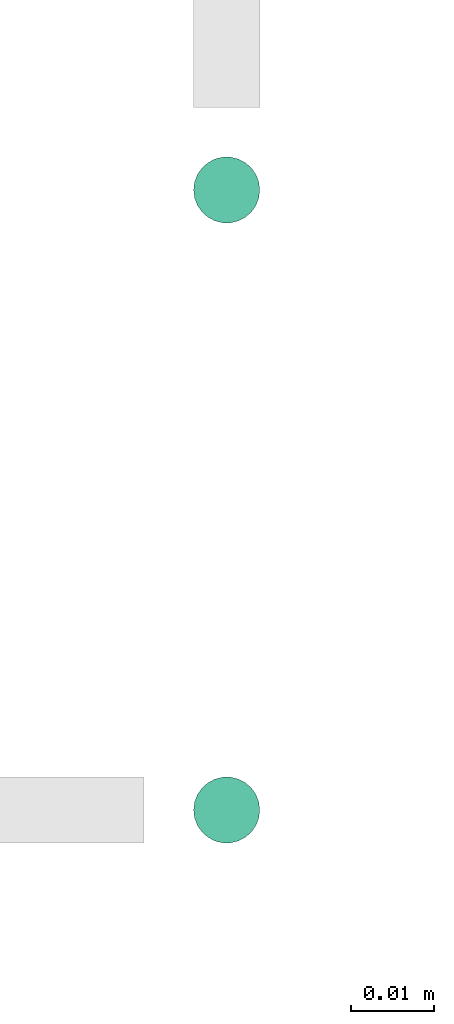
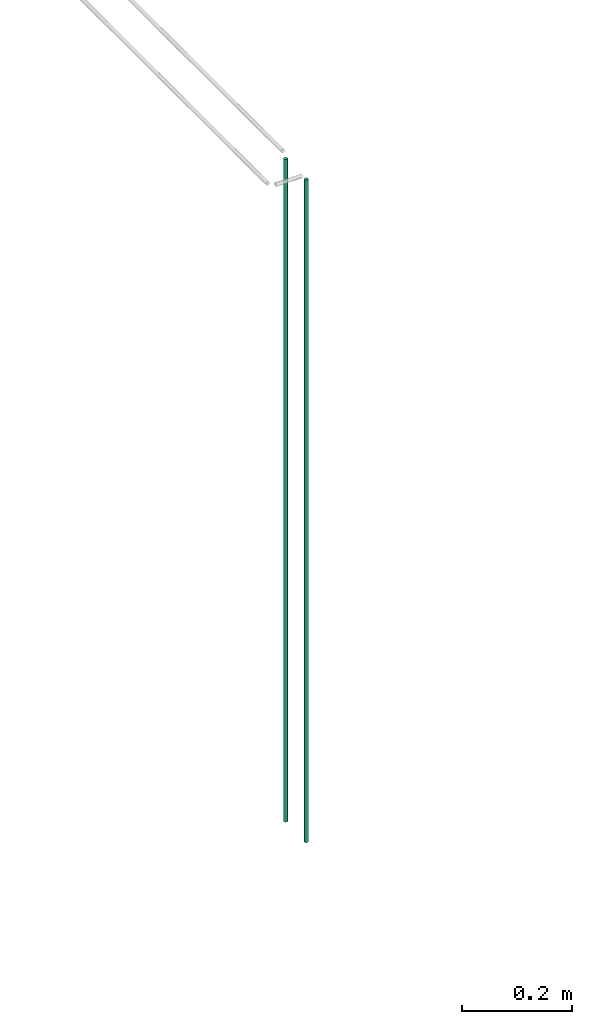
# One storey, part 10 of 89: 2 flow segments.
"""IFC2X3 building model written with IfcOpenShell, lengths in millimetres."""

from ifc_helpers import new_model, entity, si_unit, converted_unit, derived_unit, direction, frame, origin, origin_2d_with_axis, place, context, subcontext, project, spatial, circle, extrude, type_object, element, save


model = new_model("IFC2X3")

# Units and contexts
model_context = context("Model", 3, precision=0.01, world=origin(), true_north=direction((6.12303176911189e-17, 1.0)))
body_context = subcontext(model_context, "Body", "Model", "MODEL_VIEW")
ifc_project = project(units=[si_unit("LENGTHUNIT", "METRE", prefix="MILLI"), si_unit("AREAUNIT", "SQUARE_METRE"), si_unit("VOLUMEUNIT", "CUBIC_METRE"), converted_unit("PLANEANGLEUNIT", "DEGREE", entity("IfcRatioMeasure", 0.0174532925199433), si_unit("PLANEANGLEUNIT", "RADIAN"), dimensions=[0, 0, 0, 0, 0, 0, 0]), si_unit("MASSUNIT", "GRAM", prefix="KILO"), derived_unit("MASSDENSITYUNIT", [(si_unit("MASSUNIT", "GRAM", prefix="KILO"), 1), (si_unit("LENGTHUNIT", "METRE"), -3)]), derived_unit("MOMENTOFINERTIAUNIT", [(si_unit("LENGTHUNIT", "METRE"), 4)]), si_unit("TIMEUNIT", "SECOND"), si_unit("FREQUENCYUNIT", "HERTZ"), si_unit("THERMODYNAMICTEMPERATUREUNIT", "DEGREE_CELSIUS"), derived_unit("THERMALTRANSMITTANCEUNIT", [(si_unit("MASSUNIT", "GRAM", prefix="KILO"), 1), (si_unit("THERMODYNAMICTEMPERATUREUNIT", "KELVIN"), -1), (si_unit("TIMEUNIT", "SECOND"), -3)]), derived_unit("VOLUMETRICFLOWRATEUNIT", [(si_unit("LENGTHUNIT", "METRE"), 3), (si_unit("TIMEUNIT", "SECOND"), -1)]), derived_unit("MASSFLOWRATEUNIT", [(si_unit("MASSUNIT", "GRAM", prefix="KILO"), 1), (si_unit("TIMEUNIT", "SECOND"), -1)]), derived_unit("ROTATIONALFREQUENCYUNIT", [(si_unit("TIMEUNIT", "SECOND"), -1)]), si_unit("ELECTRICCURRENTUNIT", "AMPERE"), si_unit("ELECTRICVOLTAGEUNIT", "VOLT"), si_unit("POWERUNIT", "WATT"), si_unit("FORCEUNIT", "NEWTON", prefix="KILO"), si_unit("ILLUMINANCEUNIT", "LUX"), si_unit("LUMINOUSFLUXUNIT", "LUMEN"), si_unit("LUMINOUSINTENSITYUNIT", "CANDELA"), derived_unit("USERDEFINED", [(si_unit("MASSUNIT", "GRAM", prefix="KILO"), -1), (si_unit("LENGTHUNIT", "METRE"), -2), (si_unit("TIMEUNIT", "SECOND"), 3), (si_unit("LUMINOUSFLUXUNIT", "LUMEN"), 1)]), derived_unit("LINEARVELOCITYUNIT", [(si_unit("LENGTHUNIT", "METRE"), 1), (si_unit("TIMEUNIT", "SECOND"), -1)]), si_unit("PRESSUREUNIT", "PASCAL"), derived_unit("USERDEFINED", [(si_unit("LENGTHUNIT", "METRE"), -2), (si_unit("MASSUNIT", "GRAM", prefix="KILO"), 1), (si_unit("TIMEUNIT", "SECOND"), -2)]), derived_unit("LINEARFORCEUNIT", [(si_unit("MASSUNIT", "GRAM", prefix="KILO"), 1), (si_unit("LENGTHUNIT", "METRE"), 1), (si_unit("TIMEUNIT", "SECOND"), -2), (si_unit("LENGTHUNIT", "METRE"), -1)]), derived_unit("PLANARFORCEUNIT", [(si_unit("MASSUNIT", "GRAM", prefix="KILO"), 1), (si_unit("LENGTHUNIT", "METRE"), 1), (si_unit("TIMEUNIT", "SECOND"), -2), (si_unit("LENGTHUNIT", "METRE"), -2)])], contexts=[model_context])

# Site, building, storey
site_placement = place(None, frame((0.0, -0.00077364408347762, 0.0)))
site = spatial("IfcSite", under=ifc_project, at=site_placement, CompositionType="ELEMENT")
building_placement = place(site_placement, origin())
building = spatial("IfcBuilding", under=site, at=building_placement, CompositionType="ELEMENT")
storey_placement = place(building_placement, frame((0.0, 0.0, 24000.0)))
storey = spatial("IfcBuildingStorey", under=building, at=storey_placement, CompositionType="ELEMENT", Elevation=24000.0)

# Flow segments
pipe_segment_type = type_object("IfcPipeSegmentType", PredefinedType="NOTDEFINED")
for number, where in (
    (1, (48815.5947989665, 14969.1047532517, 1599.29036474498)),
    (2, (48815.5947989665, 15044.1047532517, 1599.29036474498)),
):
    element("IfcFlowSegment", number, at=place(storey_placement, frame(where)), inside=storey, type_object=pipe_segment_type, context=body_context, shape_type="SweptSolid", body=[
        extrude(circle(Radius=4.0, at=origin_2d_with_axis()), frame((5.59527223591499, 5.59527223591499, 0.0)), (0.0, 0.0, 1.0), 1465.70963525502),
    ])

save(model, "model.ifc")
